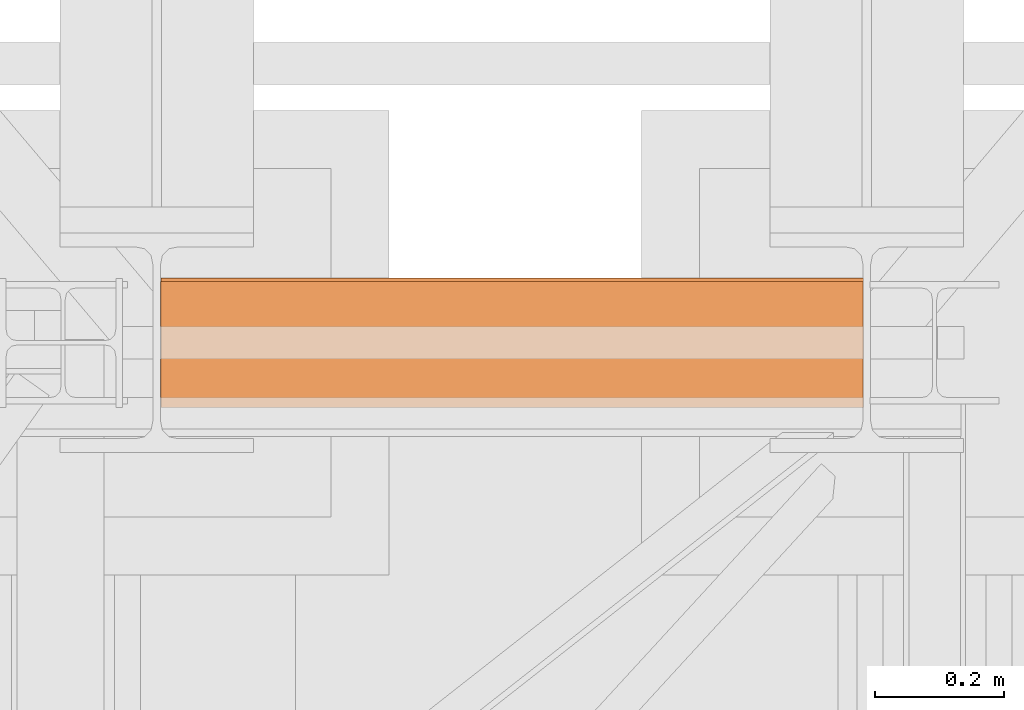
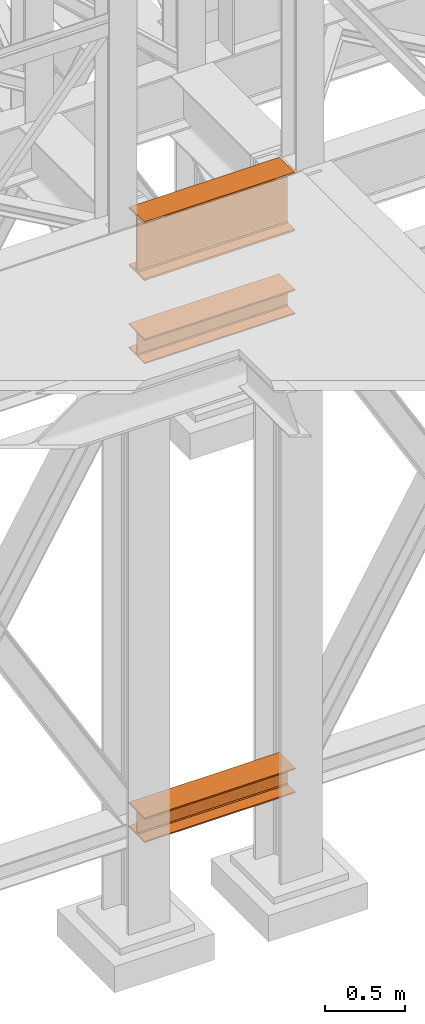
# One storey, part 78 of 208: 3 proxies.
"""IFC2X3 building model written with IfcOpenShell, lengths in millimetres."""

import ifcopenshell
import ifcopenshell.guid

model = None  # the IFC model being written
_history = None  # IfcOwnerHistory: only IFC2X3 demands one
_inside = {}  # id of a spatial element -> (the spatial element, [elements in it])
_under = {}  # id of a project, library or spatial element -> (it, [spatial elements below it])
_declared = {}  # id of a project -> (the project, [libraries it declares])
_typed = {}  # id of a type object -> (the type object, [elements of that type])
_made_of = {}  # id of a material, layer set ... -> (it, [elements and type objects made of it])


def new_model(schema):
    """Start an empty IFC model of exactly this schema.

    Asked for "IFC4X3", IfcOpenShell would pick the latest addendum, in which some entities
    have other attributes; the version numbers below select the first issue.
    IFC2X3 requires an IfcOwnerHistory on every rooted entity: one is made here for all.
    """
    global model, _history
    if schema == "IFC4X3":
        model = ifcopenshell.file(schema_version=(4, 3, 0, 0))
    else:
        model = ifcopenshell.file(schema=schema)
    _inside.clear()
    _under.clear()
    _declared.clear()
    _typed.clear()
    _made_of.clear()
    _history = None
    if model.schema == "IFC2X3":
        org = make("IfcOrganization", Name="unknown")
        user = make(
            "IfcPersonAndOrganization",
            ThePerson=make("IfcPerson", FamilyName="unknown"),
            TheOrganization=org,
        )
        app = make(
            "IfcApplication",
            ApplicationDeveloper=org,
            Version="unknown",
            ApplicationFullName="unknown",
            ApplicationIdentifier="unknown",
        )
        _history = make(
            "IfcOwnerHistory",
            OwningUser=user,
            OwningApplication=app,
            ChangeAction="ADDED",
            CreationDate=0,
        )
    return model


def make(cls, **values):
    """One entity of the class cls with the attributes given. An attribute that is None is left unset."""
    return model.create_entity(
        cls, **{name: value for name, value in values.items() if value is not None}
    )


def entity(cls, *values):
    """Any entity or typed value of the class cls, its attributes in the order of the schema. None: left unset."""
    e = model.create_entity(cls)
    for i, value in enumerate(values):
        if value is not None:
            e[i] = value
    return e


def rooted(cls, **values):
    """An entity with a GlobalId (a new one), such as an element, a storey or a relation."""
    return make(cls, GlobalId=ifcopenshell.guid.new(), OwnerHistory=_history, **values)


def si_unit(unit_type, name, prefix=None):
    """IfcSIUnit, for example si_unit("LENGTHUNIT", "METRE", prefix="MILLI")."""
    return make("IfcSIUnit", UnitType=unit_type, Prefix=prefix, Name=name)


def converted_unit(unit_type, name, factor, base, dimensions=None, offset=None):
    """IfcConversionBasedUnit, such as the inch: factor (a typed value) times the base unit."""
    return make(
        "IfcConversionBasedUnit"
        if offset is None
        else "IfcConversionBasedUnitWithOffset",
        ConversionOffset=offset,
        Dimensions=None
        if dimensions is None
        else entity("IfcDimensionalExponents", *dimensions),
        UnitType=unit_type,
        Name=name,
        ConversionFactor=make(
            "IfcMeasureWithUnit", ValueComponent=factor, UnitComponent=base
        ),
    )


def assignment(units):
    """IfcUnitAssignment: the units of a project."""
    return None if units is None else make("IfcUnitAssignment", Units=units)


def point(xyz):
    """IfcCartesianPoint."""
    return None if xyz is None else make("IfcCartesianPoint", Coordinates=xyz)


def direction(xyz):
    """IfcDirection."""
    return None if xyz is None else make("IfcDirection", DirectionRatios=xyz)


def frame(location, z_axis=None, x_axis=None):
    """IfcAxis2Placement3D, a coordinate frame: its origin and axes. An axis left out is left unset."""
    return make(
        "IfcAxis2Placement3D",
        Location=point(location),
        Axis=direction(z_axis),
        RefDirection=direction(x_axis),
    )


def origin():
    """The frame at (0, 0, 0) with its axes left unset."""
    return frame((0.0, 0.0, 0.0))


def origin_with_axes():
    """The frame at (0, 0, 0) with the z axis (0, 0, 1) and the x axis (1, 0, 0) written out."""
    return frame((0.0, 0.0, 0.0), z_axis=(0.0, 0.0, 1.0), x_axis=(1.0, 0.0, 0.0))


def place(relative_to, where):
    """IfcLocalPlacement: puts the frame where relative to a parent placement (None: the world)."""
    return make(
        "IfcLocalPlacement", PlacementRelTo=relative_to, RelativePlacement=where
    )


def context(
    kind, dimensions, precision=None, world=None, true_north=None, identifier=None
):
    """IfcGeometricRepresentationContext, for example the 3D "Model" context."""
    return make(
        "IfcGeometricRepresentationContext",
        ContextIdentifier=identifier,
        ContextType=kind,
        CoordinateSpaceDimension=dimensions,
        Precision=precision,
        WorldCoordinateSystem=world,
        TrueNorth=true_north,
    )


def subcontext(parent, identifier, kind, view, scale=None):
    """IfcGeometricRepresentationSubContext, for example "Body" below "Model"."""
    return make(
        "IfcGeometricRepresentationSubContext",
        ContextIdentifier=identifier,
        ContextType=kind,
        ParentContext=parent,
        TargetScale=scale,
        TargetView=view,
    )


def project(units=None, contexts=None):
    """IfcProject with its units and contexts."""
    return rooted(
        "IfcProject",
        Name="project",
        RepresentationContexts=contexts,
        UnitsInContext=assignment(units),
    )


def spatial(cls, under=None, at=None, **own):
    """A site, building, storey or space (cls), placed at a placement, below another one or the project."""
    s = rooted(cls, ObjectPlacement=at, **own)
    if under is not None:
        _under.setdefault(under.id(), (under, []))[1].append(s)
    return s


def faces_of(points, faces, orient=None, outer=None):
    """IfcFace entities. A face is a list of loops; a loop is a list of indices into points, from 0.

    orient and outer hold one flag for each loop. By default every Orientation is true, the
    first loop of a face is its IfcFaceOuterBound and the others are IfcFaceBound.
    """
    made = []
    for i, loops in enumerate(faces):
        bounds = []
        for j, loop in enumerate(loops):
            is_outer = j == 0 if outer is None else outer[i][j]
            bounds.append(
                make(
                    "IfcFaceOuterBound" if is_outer else "IfcFaceBound",
                    Bound=make("IfcPolyLoop", Polygon=[points[k] for k in loop]),
                    Orientation=True if orient is None else orient[i][j],
                )
            )
        made.append(make("IfcFace", Bounds=bounds))
    return made


def faceted_brep(points, faces, orient=None, outer=None, voids=None):
    """IfcFacetedBrep: a solid bounded by flat faces; with voids (closed shells), ...WithVoids."""
    shared = [point(p) for p in points]
    hull = make("IfcClosedShell", CfsFaces=faces_of(shared, faces, orient, outer))
    if voids is None:
        return make("IfcFacetedBrep", Outer=hull)
    return make(
        "IfcFacetedBrepWithVoids",
        Outer=hull,
        Voids=[
            make(cls, CfsFaces=faces_of(shared, fs, o, b)) for cls, fs, o, b in voids
        ],
    )


def shape(context_of_items, identifier, shape_type, items):
    """IfcShapeRepresentation: the items that make up one representation, for example the "Body"."""
    return make(
        "IfcShapeRepresentation",
        ContextOfItems=context_of_items,
        RepresentationIdentifier=identifier,
        RepresentationType=shape_type,
        Items=items,
    )


def made_of(thing, what):
    """Note that an element or type object is made of a material, layer set ...; save() writes the relation."""
    if what is not None:
        _made_of.setdefault(what.id(), (what, []))[1].append(thing)
    return thing


def element(
    cls,
    number,
    at=None,
    inside=None,
    cuts=None,
    type_object=None,
    material=None,
    context=None,
    identifier="Body",
    shape_type=None,
    held_by="IfcProductDefinitionShape",
    body=None,
    shapes=None,
    **own,
):
    """One element of the class cls, such as IfcWall. Its Tag is "e" and its number.

    at: its placement. inside: the storey or other place that contains it. cuts: it is an
    opening in that element (IfcRelVoidsElement). A single representation is given by context,
    identifier, shape_type and body (its items); several are given by shapes. held_by: the class
    of the entity that holds the representations. save() writes the other relations.
    """
    e = rooted(cls, Tag="e%d" % number, ObjectPlacement=at, **own)
    if body is not None:
        shapes = [shape(context, identifier, shape_type, body)]
    if shapes is not None:
        e.Representation = make(held_by, Representations=shapes)
    if inside is not None:
        _inside.setdefault(inside.id(), (inside, []))[1].append(e)
    if cuts is not None:
        rooted(
            "IfcRelVoidsElement", RelatingBuildingElement=cuts, RelatedOpeningElement=e
        )
    if type_object is not None:
        _typed.setdefault(type_object.id(), (type_object, []))[1].append(e)
    return made_of(e, material)


def aggregate(whole, parts):
    """IfcRelAggregates: a whole, such as a stair, and the parts it consists of."""
    return rooted("IfcRelAggregates", RelatingObject=whole, RelatedObjects=parts)


def save(model, path):
    """Write the relations noted so far, then the file.

    IfcRelAggregates (storeys below a building ...), IfcRelContainedInSpatialStructure (elements
    in a storey), IfcRelDefinesByType, IfcRelAssociatesMaterial and IfcRelDeclares: one each for
    every whole, place, type object, material and project.
    """
    for whole, parts in _under.values():
        aggregate(whole, parts)
    for where, things in _inside.values():
        rooted(
            "IfcRelContainedInSpatialStructure",
            RelatedElements=things,
            RelatingStructure=where,
        )
    for kind, things in _typed.values():
        rooted("IfcRelDefinesByType", RelatedObjects=things, RelatingType=kind)
    for what, things in _made_of.values():
        rooted("IfcRelAssociatesMaterial", RelatedObjects=things, RelatingMaterial=what)
    for by, libraries in _declared.values():
        rooted("IfcRelDeclares", RelatingContext=by, RelatedDefinitions=libraries)
    model.write(path)


model = new_model("IFC2X3")

# Units and contexts
model_context = context("Model", 3, precision=1e-05, world=origin())
plan_context = context("Plan", 3, precision=1e-05, world=origin())
body_context = subcontext(model_context, "Body", "Model", "MODEL_VIEW")
ifc_project = project(units=[si_unit("LENGTHUNIT", "METRE", prefix="MILLI"), converted_unit("PLANEANGLEUNIT", "DEGREE", entity("IfcPlaneAngleMeasure", 0.0174532925199433), si_unit("PLANEANGLEUNIT", "RADIAN"), dimensions=[0, 0, 0, 0, 0, 0, 0]), si_unit("AREAUNIT", "SQUARE_METRE"), si_unit("VOLUMEUNIT", "CUBIC_METRE")], contexts=[model_context, plan_context])

# Building, storey
building_placement = place(None, origin())
building = spatial("IfcBuilding", under=ifc_project, at=building_placement, CompositionType="COMPLEX")
storey_placement = place(building_placement, origin_with_axes())
storey = spatial("IfcBuildingStorey", under=building, at=storey_placement, Name="Geschoss", CompositionType="ELEMENT")

# Proxies
proxy_1_placement = place(storey_placement, frame((5500.004974593439, -17362.5323246858, 544.9900024165573), z_axis=(0.0, 0.0, 1.0), x_axis=(1.0, 0.0, 0.0)))
element("IfcBuildingElementProxy", 1, at=proxy_1_placement, inside=storey, context=body_context, shape_type="Brep", body=[
    faceted_brep([(1088.009999895692, 0.00999999999839929, 190.0100125169756), (1088.009999895692, 200.0100029802306, 190.0100125169756), (1088.009999895692, 200.0100029802306, 180.0100146031382), (1088.009999895692, 121.2600035762771, 180.0100071525576), (1088.009999895692, 111.9441915473326, 178.1454621052744), (1088.009999895692, 105.1245498640819, 171.3258190250399), (1088.009999895692, 103.2600015571697, 162.010007927418), (1088.009999895692, 103.2600015571697, 28.00999713897727), (1088.009999895692, 105.1245498640819, 18.69418604135535), (1088.009999895692, 111.9441915473326, 11.87454296112082), (1088.009999895692, 121.2600035762771, 10.00999791383765), (1088.009999895692, 200.0100029802306, 10.00999791383765), (1088.009999895692, 200.0100029802306, 0.01000000000021828), (1088.009999895692, 0.00999999999839929, 0.01000000000021828), (1088.009999895692, 0.00999999999839929, 10.00999791383765), (1088.009999895692, 78.75999940395195, 10.00999791383765), (1088.009999895692, 88.07581143289644, 11.87454296112082), (1088.009999895692, 94.89545311614711, 18.69418604135535), (1088.009999895692, 96.7600014230593, 28.00999713897727), (1088.009999895692, 96.7600014230593, 162.010007927418), (1088.009999895692, 94.89545311614711, 171.3258190250399), (1088.009999895692, 88.07581143289644, 178.1454621052744), (1088.009999895692, 78.75999940395195, 180.0100071525576), (1088.009999895692, 0.00999999999839929, 180.0100146031382), (1088.009999895692, 200.0100029802306, 190.0100125169756), (1088.009999895692, 0.00999999999839929, 190.0100125169756), (0.01000000000021828, 0.00999999999839929, 190.0100125169755), (0.01000000000021828, 200.0100029802306, 190.0100125169755), (1088.009999895692, 200.0100029802306, 180.0100146031382), (1088.009999895692, 200.0100029802306, 190.0100125169756), (0.01000000000021828, 200.0100029802306, 190.0100125169755), (0.01000000000021828, 200.0100029802306, 180.0100146031381), (1088.009999895692, 121.2600035762771, 180.0100071525576), (1088.009999895692, 200.0100029802306, 180.0100146031382), (0.01000000000021828, 200.0100029802306, 180.0100146031381), (0.01000000000021828, 121.2600035762771, 180.0100071525575), (1088.009999895692, 111.9441915473326, 178.1454621052744), (1088.009999895692, 121.2600035762771, 180.0100071525576), (0.01000000000021828, 121.2600035762771, 180.0100071525575), (0.01000000000021828, 111.9441915473326, 178.1454621052743), (1088.009999895692, 105.1245498640819, 171.3258190250399), (1088.009999895692, 111.9441915473326, 178.1454621052744), (0.01000000000021828, 111.9441915473326, 178.1454621052743), (0.01000000000021828, 105.1245498640819, 171.3258190250398), (1088.009999895692, 103.2600015571697, 162.010007927418), (1088.009999895692, 105.1245498640819, 171.3258190250399), (0.01000000000021828, 105.1245498640819, 171.3258190250398), (0.01000000000021828, 103.2600015571697, 162.0100079274179), (1088.009999895692, 103.2600015571697, 28.00999713897727), (1088.009999895692, 103.2600015571697, 162.010007927418), (0.01000000000021828, 103.2600015571697, 162.0100079274179), (0.01000000000021828, 103.2600015571697, 28.00999713897716), (1088.009999895692, 105.1245498640819, 18.69418604135535), (1088.009999895692, 103.2600015571697, 28.00999713897727), (0.01000000000021828, 103.2600015571697, 28.00999713897716), (0.01000000000021828, 105.1245498640819, 18.69418604135524), (1088.009999895692, 111.9441915473326, 11.87454296112082), (1088.009999895692, 105.1245498640819, 18.69418604135535), (0.01000000000021828, 105.1245498640819, 18.69418604135524), (0.01000000000021828, 111.9441915473326, 11.87454296112071), (1088.009999895692, 121.2600035762771, 10.00999791383765), (1088.009999895692, 111.9441915473326, 11.87454296112082), (0.01000000000021828, 111.9441915473326, 11.87454296112071), (0.01000000000021828, 121.2600035762771, 10.00999791383754), (1088.009999895692, 200.0100029802306, 10.00999791383765), (1088.009999895692, 121.2600035762771, 10.00999791383765), (0.01000000000021828, 121.2600035762771, 10.00999791383754), (0.01000000000021828, 200.0100029802306, 10.00999791383754), (1088.009999895692, 200.0100029802306, 0.01000000000021828), (1088.009999895692, 200.0100029802306, 10.00999791383765), (0.01000000000021828, 200.0100029802306, 10.00999791383754), (0.01000000000021828, 200.0100029802306, 0.01000000000010459), (1088.009999895692, 0.00999999999839929, 0.01000000000021828), (1088.009999895692, 200.0100029802306, 0.01000000000021828), (0.01000000000021828, 200.0100029802306, 0.01000000000010459), (0.01000000000021828, 0.00999999999839929, 0.01000000000010459), (1088.009999895692, 0.00999999999839929, 10.00999791383765), (1088.009999895692, 0.00999999999839929, 0.01000000000021828), (0.01000000000021828, 0.00999999999839929, 0.01000000000010459), (0.01000000000021828, 0.00999999999839929, 10.00999791383754), (1088.009999895692, 78.75999940395195, 10.00999791383765), (1088.009999895692, 0.00999999999839929, 10.00999791383765), (0.01000000000021828, 0.00999999999839929, 10.00999791383754), (0.01000000000021828, 78.75999940395195, 10.00999791383754), (1088.009999895692, 88.07581143289644, 11.87454296112082), (1088.009999895692, 78.75999940395195, 10.00999791383765), (0.01000000000021828, 78.75999940395195, 10.00999791383754), (0.01000000000021828, 88.07581143289644, 11.87454296112071), (1088.009999895692, 94.89545311614711, 18.69418604135535), (1088.009999895692, 88.07581143289644, 11.87454296112082), (0.01000000000021828, 88.07581143289644, 11.87454296112071), (0.01000000000021828, 94.89545311614711, 18.69418604135524), (1088.009999895692, 96.7600014230593, 28.00999713897727), (1088.009999895692, 94.89545311614711, 18.69418604135535), (0.01000000000021828, 94.89545311614711, 18.69418604135524), (0.01000000000021828, 96.7600014230593, 28.00999713897716), (1088.009999895692, 96.7600014230593, 162.010007927418), (1088.009999895692, 96.7600014230593, 28.00999713897727), (0.01000000000021828, 96.7600014230593, 28.00999713897716), (0.01000000000021828, 96.7600014230593, 162.0100079274179), (1088.009999895692, 94.89545311614711, 171.3258190250399), (1088.009999895692, 96.7600014230593, 162.010007927418), (0.01000000000021828, 96.7600014230593, 162.0100079274179), (0.01000000000021828, 94.89545311614711, 171.3258190250398), (1088.009999895692, 88.07581143289644, 178.1454621052744), (1088.009999895692, 94.89545311614711, 171.3258190250399), (0.01000000000021828, 94.89545311614711, 171.3258190250398), (0.01000000000021828, 88.07581143289644, 178.1454621052743), (1088.009999895692, 78.75999940395195, 180.0100071525576), (1088.009999895692, 88.07581143289644, 178.1454621052744), (0.01000000000021828, 88.07581143289644, 178.1454621052743), (0.01000000000021828, 78.75999940395195, 180.0100071525575), (1088.009999895692, 0.00999999999839929, 180.0100146031382), (1088.009999895692, 78.75999940395195, 180.0100071525576), (0.01000000000021828, 78.75999940395195, 180.0100071525575), (0.01000000000021828, 0.00999999999839929, 180.0100146031381), (1088.009999895692, 0.00999999999839929, 190.0100125169756), (1088.009999895692, 0.00999999999839929, 180.0100146031382), (0.01000000000021828, 0.00999999999839929, 180.0100146031381), (0.01000000000021828, 0.00999999999839929, 190.0100125169755), (0.01000000000021828, 0.00999999999839929, 190.0100125169755), (0.01000000000021828, 0.00999999999839929, 180.0100146031381), (0.01000000000021828, 78.75999940395195, 180.0100071525575), (0.01000000000021828, 88.07581143289644, 178.1454621052743), (0.01000000000021828, 94.89545311614711, 171.3258190250398), (0.01000000000021828, 96.7600014230593, 162.0100079274179), (0.01000000000021828, 96.7600014230593, 28.00999713897716), (0.01000000000021828, 94.89545311614711, 18.69418604135524), (0.01000000000021828, 88.07581143289644, 11.87454296112071), (0.01000000000021828, 78.75999940395195, 10.00999791383754), (0.01000000000021828, 0.00999999999839929, 10.00999791383754), (0.01000000000021828, 0.00999999999839929, 0.01000000000010459), (0.01000000000021828, 200.0100029802306, 0.01000000000010459), (0.01000000000021828, 200.0100029802306, 10.00999791383754), (0.01000000000021828, 121.2600035762771, 10.00999791383754), (0.01000000000021828, 111.9441915473326, 11.87454296112071), (0.01000000000021828, 105.1245498640819, 18.69418604135524), (0.01000000000021828, 103.2600015571697, 28.00999713897716), (0.01000000000021828, 103.2600015571697, 162.0100079274179), (0.01000000000021828, 105.1245498640819, 171.3258190250398), (0.01000000000021828, 111.9441915473326, 178.1454621052743), (0.01000000000021828, 121.2600035762771, 180.0100071525575), (0.01000000000021828, 200.0100029802306, 180.0100146031381), (0.01000000000021828, 200.0100029802306, 190.0100125169755)], [[[0, 1, 2, 3, 4, 5, 6, 7, 8, 9, 10, 11, 12, 13, 14, 15, 16, 17, 18, 19, 20, 21, 22, 23]], [[24, 25, 26, 27]], [[28, 29, 30, 31]], [[32, 33, 34, 35]], [[36, 37, 38, 39]], [[40, 41, 42, 43]], [[44, 45, 46, 47]], [[48, 49, 50, 51]], [[52, 53, 54, 55]], [[56, 57, 58, 59]], [[60, 61, 62, 63]], [[64, 65, 66, 67]], [[68, 69, 70, 71]], [[72, 73, 74, 75]], [[76, 77, 78, 79]], [[80, 81, 82, 83]], [[84, 85, 86, 87]], [[88, 89, 90, 91]], [[92, 93, 94, 95]], [[96, 97, 98, 99]], [[100, 101, 102, 103]], [[104, 105, 106, 107]], [[108, 109, 110, 111]], [[112, 113, 114, 115]], [[116, 117, 118, 119]], [[120, 121, 122, 123, 124, 125, 126, 127, 128, 129, 130, 131, 132, 133, 134, 135, 136, 137, 138, 139, 140, 141, 142, 143]]], orient=[[False], [False], [False], [False], [False], [False], [False], [False], [False], [False], [False], [False], [False], [False], [False], [False], [False], [False], [False], [False], [False], [False], [False], [False], [False], [False]]),
])
proxy_2_placement = place(storey_placement, frame((5500.004974593439, -17362.5323246858, 4202.989992847441), z_axis=(0.0, 0.0, 1.0), x_axis=(1.0, 0.0, 0.0)))
element("IfcBuildingElementProxy", 2, at=proxy_2_placement, inside=storey, context=body_context, shape_type="Brep", body=[
    faceted_brep([(1088.009999895692, 0.00999999999839929, 190.0100125169756), (1088.009999895692, 200.0100029802306, 190.0100125169756), (1088.009999895692, 200.0100029802306, 180.0100146031382), (1088.009999895692, 121.2600035762771, 180.0100071525576), (1088.009999895692, 111.9441915473326, 178.1454621052744), (1088.009999895692, 105.1245498640819, 171.3258190250399), (1088.009999895692, 103.2600015571697, 162.010007927418), (1088.009999895692, 103.2600015571697, 28.00999713897727), (1088.009999895692, 105.1245498640819, 18.69418604135535), (1088.009999895692, 111.9441915473326, 11.87454296112082), (1088.009999895692, 121.2600035762771, 10.00999791383765), (1088.009999895692, 200.0100029802306, 10.00999791383765), (1088.009999895692, 200.0100029802306, 0.01000000000021828), (1088.009999895692, 0.00999999999839929, 0.01000000000021828), (1088.009999895692, 0.00999999999839929, 10.00999791383765), (1088.009999895692, 78.75999940395195, 10.00999791383765), (1088.009999895692, 88.07581143289644, 11.87454296112082), (1088.009999895692, 94.89545311614711, 18.69418604135535), (1088.009999895692, 96.7600014230593, 28.00999713897727), (1088.009999895692, 96.7600014230593, 162.010007927418), (1088.009999895692, 94.89545311614711, 171.3258190250399), (1088.009999895692, 88.07581143289644, 178.1454621052744), (1088.009999895692, 78.75999940395195, 180.0100071525576), (1088.009999895692, 0.00999999999839929, 180.0100146031382), (1088.009999895692, 200.0100029802306, 190.0100125169756), (1088.009999895692, 0.00999999999839929, 190.0100125169756), (0.01000000000021828, 0.00999999999839929, 190.0100125169756), (0.01000000000021828, 200.0100029802306, 190.0100125169756), (1088.009999895692, 200.0100029802306, 180.0100146031382), (1088.009999895692, 200.0100029802306, 190.0100125169756), (0.01000000000021828, 200.0100029802306, 190.0100125169756), (0.01000000000021828, 200.0100029802306, 180.0100146031382), (1088.009999895692, 121.2600035762771, 180.0100071525576), (1088.009999895692, 200.0100029802306, 180.0100146031382), (0.01000000000021828, 200.0100029802306, 180.0100146031382), (0.01000000000021828, 121.2600035762771, 180.0100071525576), (1088.009999895692, 111.9441915473326, 178.1454621052744), (1088.009999895692, 121.2600035762771, 180.0100071525576), (0.01000000000021828, 121.2600035762771, 180.0100071525576), (0.01000000000021828, 111.9441915473326, 178.1454621052744), (1088.009999895692, 105.1245498640819, 171.3258190250399), (1088.009999895692, 111.9441915473326, 178.1454621052744), (0.01000000000021828, 111.9441915473326, 178.1454621052744), (0.01000000000021828, 105.1245498640819, 171.3258190250399), (1088.009999895692, 103.2600015571697, 162.010007927418), (1088.009999895692, 105.1245498640819, 171.3258190250399), (0.01000000000021828, 105.1245498640819, 171.3258190250399), (0.01000000000021828, 103.2600015571697, 162.010007927418), (1088.009999895692, 103.2600015571697, 28.00999713897727), (1088.009999895692, 103.2600015571697, 162.010007927418), (0.01000000000021828, 103.2600015571697, 162.010007927418), (0.01000000000021828, 103.2600015571697, 28.00999713897727), (1088.009999895692, 105.1245498640819, 18.69418604135535), (1088.009999895692, 103.2600015571697, 28.00999713897727), (0.01000000000021828, 103.2600015571697, 28.00999713897727), (0.01000000000021828, 105.1245498640819, 18.69418604135535), (1088.009999895692, 111.9441915473326, 11.87454296112082), (1088.009999895692, 105.1245498640819, 18.69418604135535), (0.01000000000021828, 105.1245498640819, 18.69418604135535), (0.01000000000021828, 111.9441915473326, 11.87454296112082), (1088.009999895692, 121.2600035762771, 10.00999791383765), (1088.009999895692, 111.9441915473326, 11.87454296112082), (0.01000000000021828, 111.9441915473326, 11.87454296112082), (0.01000000000021828, 121.2600035762771, 10.00999791383765), (1088.009999895692, 200.0100029802306, 10.00999791383765), (1088.009999895692, 121.2600035762771, 10.00999791383765), (0.01000000000021828, 121.2600035762771, 10.00999791383765), (0.01000000000021828, 200.0100029802306, 10.00999791383765), (1088.009999895692, 200.0100029802306, 0.01000000000021828), (1088.009999895692, 200.0100029802306, 10.00999791383765), (0.01000000000021828, 200.0100029802306, 10.00999791383765), (0.01000000000021828, 200.0100029802306, 0.01000000000021828), (1088.009999895692, 0.00999999999839929, 0.01000000000021828), (1088.009999895692, 200.0100029802306, 0.01000000000021828), (0.01000000000021828, 200.0100029802306, 0.01000000000021828), (0.01000000000021828, 0.00999999999839929, 0.01000000000021828), (1088.009999895692, 0.00999999999839929, 10.00999791383765), (1088.009999895692, 0.00999999999839929, 0.01000000000021828), (0.01000000000021828, 0.00999999999839929, 0.01000000000021828), (0.01000000000021828, 0.00999999999839929, 10.00999791383765), (1088.009999895692, 78.75999940395195, 10.00999791383765), (1088.009999895692, 0.00999999999839929, 10.00999791383765), (0.01000000000021828, 0.00999999999839929, 10.00999791383765), (0.01000000000021828, 78.75999940395195, 10.00999791383765), (1088.009999895692, 88.07581143289644, 11.87454296112082), (1088.009999895692, 78.75999940395195, 10.00999791383765), (0.01000000000021828, 78.75999940395195, 10.00999791383765), (0.01000000000021828, 88.07581143289644, 11.87454296112082), (1088.009999895692, 94.89545311614711, 18.69418604135535), (1088.009999895692, 88.07581143289644, 11.87454296112082), (0.01000000000021828, 88.07581143289644, 11.87454296112082), (0.01000000000021828, 94.89545311614711, 18.69418604135535), (1088.009999895692, 96.7600014230593, 28.00999713897727), (1088.009999895692, 94.89545311614711, 18.69418604135535), (0.01000000000021828, 94.89545311614711, 18.69418604135535), (0.01000000000021828, 96.7600014230593, 28.00999713897727), (1088.009999895692, 96.7600014230593, 162.010007927418), (1088.009999895692, 96.7600014230593, 28.00999713897727), (0.01000000000021828, 96.7600014230593, 28.00999713897727), (0.01000000000021828, 96.7600014230593, 162.010007927418), (1088.009999895692, 94.89545311614711, 171.3258190250399), (1088.009999895692, 96.7600014230593, 162.010007927418), (0.01000000000021828, 96.7600014230593, 162.010007927418), (0.01000000000021828, 94.89545311614711, 171.3258190250399), (1088.009999895692, 88.07581143289644, 178.1454621052744), (1088.009999895692, 94.89545311614711, 171.3258190250399), (0.01000000000021828, 94.89545311614711, 171.3258190250399), (0.01000000000021828, 88.07581143289644, 178.1454621052744), (1088.009999895692, 78.75999940395195, 180.0100071525576), (1088.009999895692, 88.07581143289644, 178.1454621052744), (0.01000000000021828, 88.07581143289644, 178.1454621052744), (0.01000000000021828, 78.75999940395195, 180.0100071525576), (1088.009999895692, 0.00999999999839929, 180.0100146031382), (1088.009999895692, 78.75999940395195, 180.0100071525576), (0.01000000000021828, 78.75999940395195, 180.0100071525576), (0.01000000000021828, 0.00999999999839929, 180.0100146031382), (1088.009999895692, 0.00999999999839929, 190.0100125169756), (1088.009999895692, 0.00999999999839929, 180.0100146031382), (0.01000000000021828, 0.00999999999839929, 180.0100146031382), (0.01000000000021828, 0.00999999999839929, 190.0100125169756), (0.01000000000021828, 0.00999999999839929, 190.0100125169756), (0.01000000000021828, 0.00999999999839929, 180.0100146031382), (0.01000000000021828, 78.75999940395195, 180.0100071525576), (0.01000000000021828, 88.07581143289644, 178.1454621052744), (0.01000000000021828, 94.89545311614711, 171.3258190250399), (0.01000000000021828, 96.7600014230593, 162.010007927418), (0.01000000000021828, 96.7600014230593, 28.00999713897727), (0.01000000000021828, 94.89545311614711, 18.69418604135535), (0.01000000000021828, 88.07581143289644, 11.87454296112082), (0.01000000000021828, 78.75999940395195, 10.00999791383765), (0.01000000000021828, 0.00999999999839929, 10.00999791383765), (0.01000000000021828, 0.00999999999839929, 0.01000000000021828), (0.01000000000021828, 200.0100029802306, 0.01000000000021828), (0.01000000000021828, 200.0100029802306, 10.00999791383765), (0.01000000000021828, 121.2600035762771, 10.00999791383765), (0.01000000000021828, 111.9441915473326, 11.87454296112082), (0.01000000000021828, 105.1245498640819, 18.69418604135535), (0.01000000000021828, 103.2600015571697, 28.00999713897727), (0.01000000000021828, 103.2600015571697, 162.010007927418), (0.01000000000021828, 105.1245498640819, 171.3258190250399), (0.01000000000021828, 111.9441915473326, 178.1454621052744), (0.01000000000021828, 121.2600035762771, 180.0100071525576), (0.01000000000021828, 200.0100029802306, 180.0100146031382), (0.01000000000021828, 200.0100029802306, 190.0100125169756)], [[[0, 1, 2, 3, 4, 5, 6, 7, 8, 9, 10, 11, 12, 13, 14, 15, 16, 17, 18, 19, 20, 21, 22, 23]], [[24, 25, 26, 27]], [[28, 29, 30, 31]], [[32, 33, 34, 35]], [[36, 37, 38, 39]], [[40, 41, 42, 43]], [[44, 45, 46, 47]], [[48, 49, 50, 51]], [[52, 53, 54, 55]], [[56, 57, 58, 59]], [[60, 61, 62, 63]], [[64, 65, 66, 67]], [[68, 69, 70, 71]], [[72, 73, 74, 75]], [[76, 77, 78, 79]], [[80, 81, 82, 83]], [[84, 85, 86, 87]], [[88, 89, 90, 91]], [[92, 93, 94, 95]], [[96, 97, 98, 99]], [[100, 101, 102, 103]], [[104, 105, 106, 107]], [[108, 109, 110, 111]], [[112, 113, 114, 115]], [[116, 117, 118, 119]], [[120, 121, 122, 123, 124, 125, 126, 127, 128, 129, 130, 131, 132, 133, 134, 135, 136, 137, 138, 139, 140, 141, 142, 143]]], orient=[[False], [False], [False], [False], [False], [False], [False], [False], [False], [False], [False], [False], [False], [False], [False], [False], [False], [False], [False], [False], [False], [False], [False], [False], [False], [False]]),
])
proxy_3_placement = place(storey_placement, frame((5499.254968580828, -17357.574399786, 4834.989987483023), z_axis=(0.0, 0.0, 1.0), x_axis=(1.0, 0.0, 0.0)))
element("IfcBuildingElementProxy", 3, at=proxy_3_placement, inside=storey, context=body_context, shape_type="Brep", body=[
    faceted_brep([(1088.009999895696, 0.00999999999839929, 450.0100178813937), (1088.009999895696, 190.0100125169738, 450.0100178813937), (1088.009999895696, 190.0100125169738, 435.4100240564349), (1088.009999895696, 120.7100073045476, 435.4100091552737), (1088.009999895696, 109.8415622657522, 433.2347078418734), (1088.009999895696, 101.8853126263603, 425.2784563398363), (1088.009999895696, 99.71000619068582, 414.4100113010409), (1088.009999895696, 99.71000619068582, 35.60999167919181), (1088.009999895696, 101.8853126263603, 24.74154664039634), (1088.009999895696, 109.8415622657522, 16.78529513835929), (1088.009999895696, 120.7100073045476, 14.60999382495902), (1088.009999895696, 190.0100125169738, 14.60999382495902), (1088.009999895696, 190.0100125169738, 0.01000000000021828), (1088.009999895696, 0.00999999999839929, 0.01000000000021828), (1088.009999895696, 0.00999999999839929, 14.60999382495902), (1088.009999895696, 69.31000521242458, 14.60999382495902), (1088.009999895696, 80.17845025122006, 16.78529513835929), (1088.009999895696, 88.13469989061196, 24.74154664039634), (1088.009999895696, 90.31000632628638, 35.60999167919181), (1088.009999895696, 90.31000632628638, 414.4100113010409), (1088.009999895696, 88.13469989061196, 425.2784563398363), (1088.009999895696, 80.17845025122006, 433.2347078418734), (1088.009999895696, 69.31000521242458, 435.4100091552737), (1088.009999895696, 0.00999999999839929, 435.4100240564349), (1088.009999895696, 190.0100125169738, 450.0100178813937), (1088.009999895696, 0.00999999999839929, 450.0100178813937), (0.01000000000021828, 0.00999999999839929, 450.0100178813937), (0.01000000000021828, 190.0100125169738, 450.0100178813937), (1088.009999895696, 190.0100125169738, 435.4100240564349), (1088.009999895696, 190.0100125169738, 450.0100178813937), (0.01000000000021828, 190.0100125169738, 450.0100178813937), (0.01000000000021828, 190.0100125169738, 435.4100240564349), (1088.009999895696, 120.7100073045476, 435.4100091552737), (1088.009999895696, 190.0100125169738, 435.4100240564349), (0.01000000000021828, 190.0100125169738, 435.4100240564349), (0.01000000000021828, 120.7100073045476, 435.4100091552737), (1088.009999895696, 109.8415622657522, 433.2347078418734), (1088.009999895696, 120.7100073045476, 435.4100091552737), (0.01000000000021828, 120.7100073045476, 435.4100091552737), (0.01000000000021828, 109.8415622657522, 433.2347078418734), (1088.009999895696, 101.8853126263603, 425.2784563398363), (1088.009999895696, 109.8415622657522, 433.2347078418734), (0.01000000000021828, 109.8415622657522, 433.2347078418734), (0.01000000000021828, 101.8853126263603, 425.2784563398363), (1088.009999895696, 99.71000619068582, 414.4100113010409), (1088.009999895696, 101.8853126263603, 425.2784563398363), (0.01000000000021828, 101.8853126263603, 425.2784563398363), (0.01000000000021828, 99.71000619068582, 414.4100113010409), (1088.009999895696, 99.71000619068582, 35.60999167919181), (1088.009999895696, 99.71000619068582, 414.4100113010409), (0.01000000000021828, 99.71000619068582, 414.4100113010409), (0.01000000000021828, 99.71000619068582, 35.60999167919181), (1088.009999895696, 101.8853126263603, 24.74154664039634), (1088.009999895696, 99.71000619068582, 35.60999167919181), (0.01000000000021828, 99.71000619068582, 35.60999167919181), (0.01000000000021828, 101.8853126263603, 24.74154664039634), (1088.009999895696, 109.8415622657522, 16.78529513835929), (1088.009999895696, 101.8853126263603, 24.74154664039634), (0.01000000000021828, 101.8853126263603, 24.74154664039634), (0.01000000000021828, 109.8415622657522, 16.78529513835929), (1088.009999895696, 120.7100073045476, 14.60999382495902), (1088.009999895696, 109.8415622657522, 16.78529513835929), (0.01000000000021828, 109.8415622657522, 16.78529513835929), (0.01000000000021828, 120.7100073045476, 14.60999382495902), (1088.009999895696, 190.0100125169738, 14.60999382495902), (1088.009999895696, 120.7100073045476, 14.60999382495902), (0.01000000000021828, 120.7100073045476, 14.60999382495902), (0.01000000000021828, 190.0100125169738, 14.60999382495902), (1088.009999895696, 190.0100125169738, 0.01000000000021828), (1088.009999895696, 190.0100125169738, 14.60999382495902), (0.01000000000021828, 190.0100125169738, 14.60999382495902), (0.01000000000021828, 190.0100125169738, 0.01000000000021828), (1088.009999895696, 0.00999999999839929, 0.01000000000021828), (1088.009999895696, 190.0100125169738, 0.01000000000021828), (0.01000000000021828, 190.0100125169738, 0.01000000000021828), (0.01000000000021828, 0.00999999999839929, 0.01000000000021828), (1088.009999895696, 0.00999999999839929, 14.60999382495902), (1088.009999895696, 0.00999999999839929, 0.01000000000021828), (0.01000000000021828, 0.00999999999839929, 0.01000000000021828), (0.01000000000021828, 0.00999999999839929, 14.60999382495902), (1088.009999895696, 69.31000521242458, 14.60999382495902), (1088.009999895696, 0.00999999999839929, 14.60999382495902), (0.01000000000021828, 0.00999999999839929, 14.60999382495902), (0.01000000000021828, 69.31000521242458, 14.60999382495902), (1088.009999895696, 80.17845025122006, 16.78529513835929), (1088.009999895696, 69.31000521242458, 14.60999382495902), (0.01000000000021828, 69.31000521242458, 14.60999382495902), (0.01000000000021828, 80.17845025122006, 16.78529513835929), (1088.009999895696, 88.13469989061196, 24.74154664039634), (1088.009999895696, 80.17845025122006, 16.78529513835929), (0.01000000000021828, 80.17845025122006, 16.78529513835929), (0.01000000000021828, 88.13469989061196, 24.74154664039634), (1088.009999895696, 90.31000632628638, 35.60999167919181), (1088.009999895696, 88.13469989061196, 24.74154664039634), (0.01000000000021828, 88.13469989061196, 24.74154664039634), (0.01000000000021828, 90.31000632628638, 35.60999167919181), (1088.009999895696, 90.31000632628638, 414.4100113010409), (1088.009999895696, 90.31000632628638, 35.60999167919181), (0.01000000000021828, 90.31000632628638, 35.60999167919181), (0.01000000000021828, 90.31000632628638, 414.4100113010409), (1088.009999895696, 88.13469989061196, 425.2784563398363), (1088.009999895696, 90.31000632628638, 414.4100113010409), (0.01000000000021828, 90.31000632628638, 414.4100113010409), (0.01000000000021828, 88.13469989061196, 425.2784563398363), (1088.009999895696, 80.17845025122006, 433.2347078418734), (1088.009999895696, 88.13469989061196, 425.2784563398363), (0.01000000000021828, 88.13469989061196, 425.2784563398363), (0.01000000000021828, 80.17845025122006, 433.2347078418734), (1088.009999895696, 69.31000521242458, 435.4100091552737), (1088.009999895696, 80.17845025122006, 433.2347078418734), (0.01000000000021828, 80.17845025122006, 433.2347078418734), (0.01000000000021828, 69.31000521242458, 435.4100091552737), (1088.009999895696, 0.00999999999839929, 435.4100240564349), (1088.009999895696, 69.31000521242458, 435.4100091552737), (0.01000000000021828, 69.31000521242458, 435.4100091552737), (0.01000000000021828, 0.00999999999839929, 435.4100240564349), (1088.009999895696, 0.00999999999839929, 450.0100178813937), (1088.009999895696, 0.00999999999839929, 435.4100240564349), (0.01000000000021828, 0.00999999999839929, 435.4100240564349), (0.01000000000021828, 0.00999999999839929, 450.0100178813937), (0.01000000000021828, 0.00999999999839929, 450.0100178813937), (0.01000000000021828, 0.00999999999839929, 435.4100240564349), (0.01000000000021828, 69.31000521242458, 435.4100091552737), (0.01000000000021828, 80.17845025122006, 433.2347078418734), (0.01000000000021828, 88.13469989061196, 425.2784563398363), (0.01000000000021828, 90.31000632628638, 414.4100113010409), (0.01000000000021828, 90.31000632628638, 35.60999167919181), (0.01000000000021828, 88.13469989061196, 24.74154664039634), (0.01000000000021828, 80.17845025122006, 16.78529513835929), (0.01000000000021828, 69.31000521242458, 14.60999382495902), (0.01000000000021828, 0.00999999999839929, 14.60999382495902), (0.01000000000021828, 0.00999999999839929, 0.01000000000021828), (0.01000000000021828, 190.0100125169738, 0.01000000000021828), (0.01000000000021828, 190.0100125169738, 14.60999382495902), (0.01000000000021828, 120.7100073045476, 14.60999382495902), (0.01000000000021828, 109.8415622657522, 16.78529513835929), (0.01000000000021828, 101.8853126263603, 24.74154664039634), (0.01000000000021828, 99.71000619068582, 35.60999167919181), (0.01000000000021828, 99.71000619068582, 414.4100113010409), (0.01000000000021828, 101.8853126263603, 425.2784563398363), (0.01000000000021828, 109.8415622657522, 433.2347078418734), (0.01000000000021828, 120.7100073045476, 435.4100091552737), (0.01000000000021828, 190.0100125169738, 435.4100240564349), (0.01000000000021828, 190.0100125169738, 450.0100178813937)], [[[0, 1, 2, 3, 4, 5, 6, 7, 8, 9, 10, 11, 12, 13, 14, 15, 16, 17, 18, 19, 20, 21, 22, 23]], [[24, 25, 26, 27]], [[28, 29, 30, 31]], [[32, 33, 34, 35]], [[36, 37, 38, 39]], [[40, 41, 42, 43]], [[44, 45, 46, 47]], [[48, 49, 50, 51]], [[52, 53, 54, 55]], [[56, 57, 58, 59]], [[60, 61, 62, 63]], [[64, 65, 66, 67]], [[68, 69, 70, 71]], [[72, 73, 74, 75]], [[76, 77, 78, 79]], [[80, 81, 82, 83]], [[84, 85, 86, 87]], [[88, 89, 90, 91]], [[92, 93, 94, 95]], [[96, 97, 98, 99]], [[100, 101, 102, 103]], [[104, 105, 106, 107]], [[108, 109, 110, 111]], [[112, 113, 114, 115]], [[116, 117, 118, 119]], [[120, 121, 122, 123, 124, 125, 126, 127, 128, 129, 130, 131, 132, 133, 134, 135, 136, 137, 138, 139, 140, 141, 142, 143]]], orient=[[False], [False], [False], [False], [False], [False], [False], [False], [False], [False], [False], [False], [False], [False], [False], [False], [False], [False], [False], [False], [False], [False], [False], [False], [False], [False]]),
])

save(model, "model.ifc")
